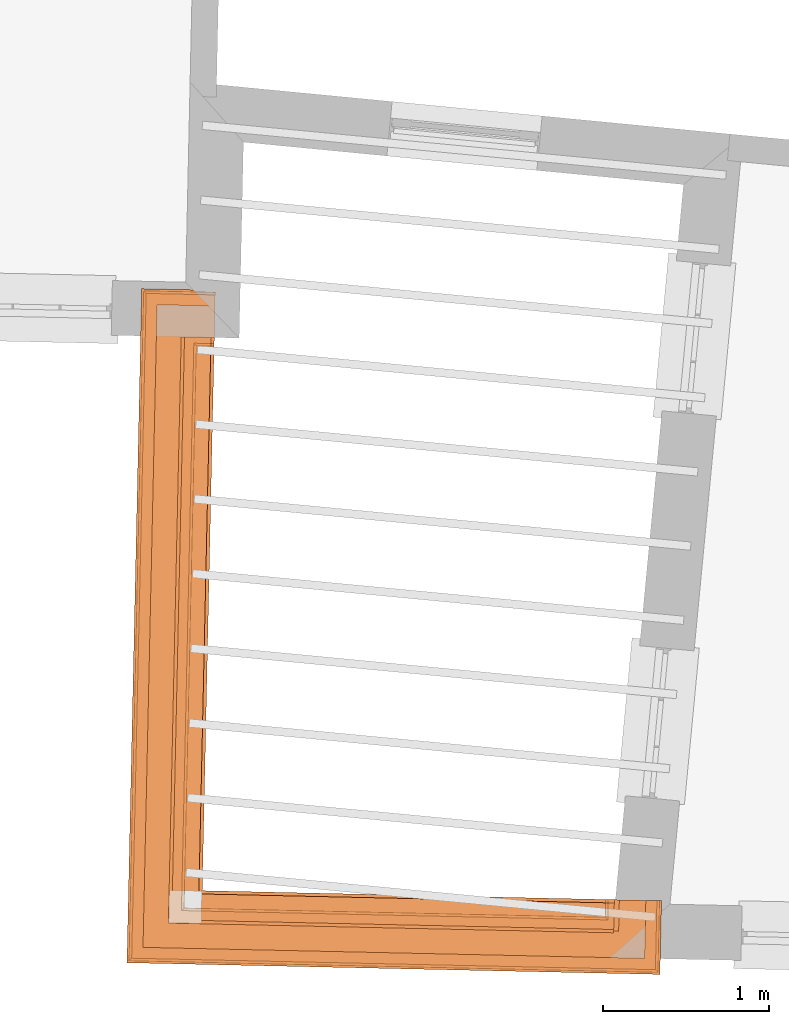
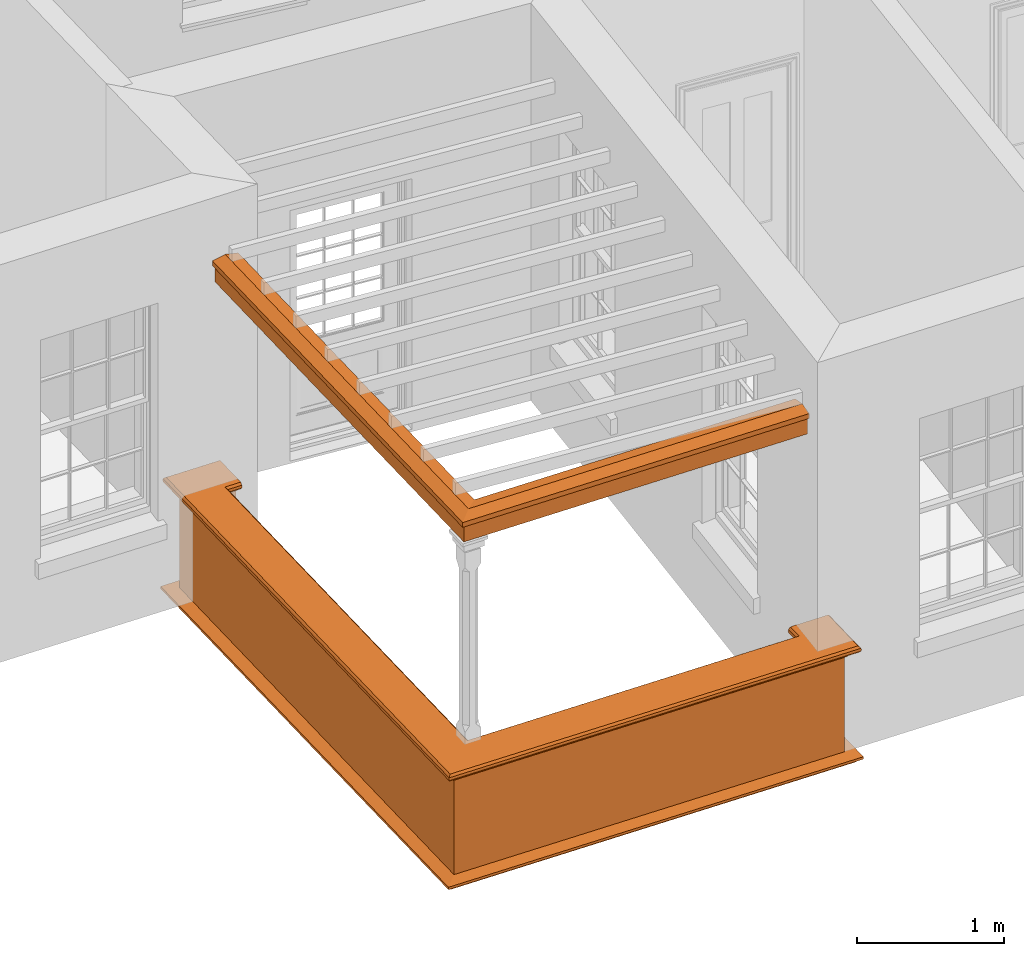
# One storey, part 11 of 12: 5 proxies.
"""IFC2X3 building model written with IfcOpenShell, lengths in metres."""

import ifcopenshell
import ifcopenshell.guid

model = None  # the IFC model being written
_history = None  # IfcOwnerHistory: only IFC2X3 demands one
_inside = {}  # id of a spatial element -> (the spatial element, [elements in it])
_under = {}  # id of a project, library or spatial element -> (it, [spatial elements below it])
_declared = {}  # id of a project -> (the project, [libraries it declares])
_typed = {}  # id of a type object -> (the type object, [elements of that type])
_made_of = {}  # id of a material, layer set ... -> (it, [elements and type objects made of it])


def new_model(schema):
    """Start an empty IFC model of exactly this schema.

    Asked for "IFC4X3", IfcOpenShell would pick the latest addendum, in which some entities
    have other attributes; the version numbers below select the first issue.
    IFC2X3 requires an IfcOwnerHistory on every rooted entity: one is made here for all.
    """
    global model, _history
    if schema == "IFC4X3":
        model = ifcopenshell.file(schema_version=(4, 3, 0, 0))
    else:
        model = ifcopenshell.file(schema=schema)
    _inside.clear()
    _under.clear()
    _declared.clear()
    _typed.clear()
    _made_of.clear()
    _history = None
    if model.schema == "IFC2X3":
        org = make("IfcOrganization", Name="unknown")
        user = make(
            "IfcPersonAndOrganization",
            ThePerson=make("IfcPerson", FamilyName="unknown"),
            TheOrganization=org,
        )
        app = make(
            "IfcApplication",
            ApplicationDeveloper=org,
            Version="unknown",
            ApplicationFullName="unknown",
            ApplicationIdentifier="unknown",
        )
        _history = make(
            "IfcOwnerHistory",
            OwningUser=user,
            OwningApplication=app,
            ChangeAction="ADDED",
            CreationDate=0,
        )
    return model


def make(cls, **values):
    """One entity of the class cls with the attributes given. An attribute that is None is left unset."""
    return model.create_entity(
        cls, **{name: value for name, value in values.items() if value is not None}
    )


def entity(cls, *values):
    """Any entity or typed value of the class cls, its attributes in the order of the schema. None: left unset."""
    e = model.create_entity(cls)
    for i, value in enumerate(values):
        if value is not None:
            e[i] = value
    return e


def rooted(cls, **values):
    """An entity with a GlobalId (a new one), such as an element, a storey or a relation."""
    return make(cls, GlobalId=ifcopenshell.guid.new(), OwnerHistory=_history, **values)


def si_unit(unit_type, name, prefix=None):
    """IfcSIUnit, for example si_unit("LENGTHUNIT", "METRE", prefix="MILLI")."""
    return make("IfcSIUnit", UnitType=unit_type, Prefix=prefix, Name=name)


def assignment(units):
    """IfcUnitAssignment: the units of a project."""
    return None if units is None else make("IfcUnitAssignment", Units=units)


def point(xyz):
    """IfcCartesianPoint."""
    return None if xyz is None else make("IfcCartesianPoint", Coordinates=xyz)


def direction(xyz):
    """IfcDirection."""
    return None if xyz is None else make("IfcDirection", DirectionRatios=xyz)


def frame(location, z_axis=None, x_axis=None):
    """IfcAxis2Placement3D, a coordinate frame: its origin and axes. An axis left out is left unset."""
    return make(
        "IfcAxis2Placement3D",
        Location=point(location),
        Axis=direction(z_axis),
        RefDirection=direction(x_axis),
    )


def origin():
    """The frame at (0, 0, 0) with its axes left unset."""
    return frame((0.0, 0.0, 0.0))


def place(relative_to, where):
    """IfcLocalPlacement: puts the frame where relative to a parent placement (None: the world)."""
    return make(
        "IfcLocalPlacement", PlacementRelTo=relative_to, RelativePlacement=where
    )


def context(
    kind, dimensions, precision=None, world=None, true_north=None, identifier=None
):
    """IfcGeometricRepresentationContext, for example the 3D "Model" context."""
    return make(
        "IfcGeometricRepresentationContext",
        ContextIdentifier=identifier,
        ContextType=kind,
        CoordinateSpaceDimension=dimensions,
        Precision=precision,
        WorldCoordinateSystem=world,
        TrueNorth=true_north,
    )


def subcontext(parent, identifier, kind, view, scale=None):
    """IfcGeometricRepresentationSubContext, for example "Body" below "Model"."""
    return make(
        "IfcGeometricRepresentationSubContext",
        ContextIdentifier=identifier,
        ContextType=kind,
        ParentContext=parent,
        TargetScale=scale,
        TargetView=view,
    )


def project(units=None, contexts=None):
    """IfcProject with its units and contexts."""
    return rooted(
        "IfcProject",
        Name="project",
        RepresentationContexts=contexts,
        UnitsInContext=assignment(units),
    )


def spatial(cls, under=None, at=None, **own):
    """A site, building, storey or space (cls), placed at a placement, below another one or the project."""
    s = rooted(cls, ObjectPlacement=at, **own)
    if under is not None:
        _under.setdefault(under.id(), (under, []))[1].append(s)
    return s


def shape(context_of_items, identifier, shape_type, items):
    """IfcShapeRepresentation: the items that make up one representation, for example the "Body"."""
    return make(
        "IfcShapeRepresentation",
        ContextOfItems=context_of_items,
        RepresentationIdentifier=identifier,
        RepresentationType=shape_type,
        Items=items,
    )


def made_of(thing, what):
    """Note that an element or type object is made of a material, layer set ...; save() writes the relation."""
    if what is not None:
        _made_of.setdefault(what.id(), (what, []))[1].append(thing)
    return thing


def element(
    cls,
    number,
    at=None,
    inside=None,
    cuts=None,
    type_object=None,
    material=None,
    context=None,
    identifier="Body",
    shape_type=None,
    held_by="IfcProductDefinitionShape",
    body=None,
    shapes=None,
    **own,
):
    """One element of the class cls, such as IfcWall. Its Tag is "e" and its number.

    at: its placement. inside: the storey or other place that contains it. cuts: it is an
    opening in that element (IfcRelVoidsElement). A single representation is given by context,
    identifier, shape_type and body (its items); several are given by shapes. held_by: the class
    of the entity that holds the representations. save() writes the other relations.
    """
    e = rooted(cls, Tag="e%d" % number, ObjectPlacement=at, **own)
    if body is not None:
        shapes = [shape(context, identifier, shape_type, body)]
    if shapes is not None:
        e.Representation = make(held_by, Representations=shapes)
    if inside is not None:
        _inside.setdefault(inside.id(), (inside, []))[1].append(e)
    if cuts is not None:
        rooted(
            "IfcRelVoidsElement", RelatingBuildingElement=cuts, RelatedOpeningElement=e
        )
    if type_object is not None:
        _typed.setdefault(type_object.id(), (type_object, []))[1].append(e)
    return made_of(e, material)


def aggregate(whole, parts):
    """IfcRelAggregates: a whole, such as a stair, and the parts it consists of."""
    return rooted("IfcRelAggregates", RelatingObject=whole, RelatedObjects=parts)


def save(model, path):
    """Write the relations noted so far, then the file.

    IfcRelAggregates (storeys below a building ...), IfcRelContainedInSpatialStructure (elements
    in a storey), IfcRelDefinesByType, IfcRelAssociatesMaterial and IfcRelDeclares: one each for
    every whole, place, type object, material and project.
    """
    for whole, parts in _under.values():
        aggregate(whole, parts)
    for where, things in _inside.values():
        rooted(
            "IfcRelContainedInSpatialStructure",
            RelatedElements=things,
            RelatingStructure=where,
        )
    for kind, things in _typed.values():
        rooted("IfcRelDefinesByType", RelatedObjects=things, RelatingType=kind)
    for what, things in _made_of.values():
        rooted("IfcRelAssociatesMaterial", RelatedObjects=things, RelatingMaterial=what)
    for by, libraries in _declared.values():
        rooted("IfcRelDeclares", RelatingContext=by, RelatedDefinitions=libraries)
    model.write(path)


model = new_model("IFC2X3")

# Units and contexts
model_context = context("Model", 3, world=origin())
body_context = subcontext(model_context, "Body", "Model", "MODEL_VIEW")
ifc_project = project(units=[si_unit("PLANEANGLEUNIT", "RADIAN"), si_unit("MASSUNIT", "GRAM", prefix="KILO"), si_unit("FORCEUNIT", "NEWTON", prefix="KILO"), si_unit("LENGTHUNIT", "METRE")], contexts=[model_context])

# Site, building, storey
site_placement = place(None, origin())
site = spatial("IfcSite", under=ifc_project, at=site_placement, CompositionType="ELEMENT")
building_placement = place(None, origin())
building = spatial("IfcBuilding", under=site, at=building_placement, Name="Building plot-18", CompositionType="ELEMENT")
storey_placement = place(None, frame((0.0, 0.0, 6.6)))
storey = spatial("IfcBuildingStorey", under=building, at=storey_placement, Name="Floor 1", CompositionType="ELEMENT", Elevation=6.6)

# Proxies
proxy_1_placement = place(storey_placement, origin())
axis2_placement3_d_1 = entity("IfcAxis2Placement3D", entity("IfcCartesianPoint", [0.0, 0.0, 0.0]))
element("IfcBuildingElementProxy", 1, at=proxy_1_placement, inside=storey, Name="parapet", CompositionType="ELEMENT", context=body_context, shape_type="SweptSolid", held_by="IfcProductRepresentation", body=[
    entity("IfcSurfaceCurveSweptAreaSolid", entity("IfcArbitraryClosedProfileDef", "AREA", None, entity("IfcPolyline", [entity("IfcCartesianPoint", [0.0, 0.25]), entity("IfcCartesianPoint", [0.795, 0.25]), entity("IfcCartesianPoint", [0.795, 0.09]), entity("IfcCartesianPoint", [0.02, 0.09]), entity("IfcCartesianPoint", [0.02, -0.08]), entity("IfcCartesianPoint", [0.0, -0.08]), entity("IfcCartesianPoint", [0.0, 0.25])])), axis2_placement3_d_1, entity("IfcPolyline", [entity("IfcCartesianPoint", [94.0271799475913, 20.2531681864854]), entity("IfcCartesianPoint", [93.9272038588954, 20.2553548938428]), entity("IfcCartesianPoint", [93.8532821448265, 16.875659930283]), entity("IfcCartesianPoint", [96.3815064977271, 16.820361839854]), entity("IfcCartesianPoint", [96.3836932050844, 16.9203379285499])]), 0.0, 1.0, entity("IfcPlane", axis2_placement3_d_1)),
])
proxy_2_placement = place(storey_placement, origin())
axis2_placement3_d_2 = entity("IfcAxis2Placement3D", entity("IfcCartesianPoint", [0.0, 0.0, 0.0]))
element("IfcBuildingElementProxy", 2, at=proxy_2_placement, inside=storey, Name="parapet", CompositionType="ELEMENT", context=body_context, shape_type="SweptSolid", held_by="IfcProductRepresentation", body=[
    entity("IfcSurfaceCurveSweptAreaSolid", entity("IfcArbitraryClosedProfileDef", "AREA", None, entity("IfcPolyline", [entity("IfcCartesianPoint", [0.795, 0.265]), entity("IfcCartesianPoint", [0.807, 0.268]), entity("IfcCartesianPoint", [0.816, 0.274]), entity("IfcCartesianPoint", [0.822, 0.283]), entity("IfcCartesianPoint", [0.825, 0.295]), entity("IfcCartesianPoint", [0.84, 0.295]), entity("IfcCartesianPoint", [0.84, 0.305]), entity("IfcCartesianPoint", [0.842, 0.317]), entity("IfcCartesianPoint", [0.849, 0.326]), entity("IfcCartesianPoint", [0.858, 0.333]), entity("IfcCartesianPoint", [0.87, 0.335]), entity("IfcCartesianPoint", [0.882, 0.333]), entity("IfcCartesianPoint", [0.891, 0.326]), entity("IfcCartesianPoint", [0.898, 0.317]), entity("IfcCartesianPoint", [0.9, 0.305]), entity("IfcCartesianPoint", [0.9, 0.035]), entity("IfcCartesianPoint", [0.898, 0.023]), entity("IfcCartesianPoint", [0.891, 0.014]), entity("IfcCartesianPoint", [0.882, 0.007]), entity("IfcCartesianPoint", [0.87, 0.005]), entity("IfcCartesianPoint", [0.858, 0.007]), entity("IfcCartesianPoint", [0.849, 0.014]), entity("IfcCartesianPoint", [0.842, 0.023]), entity("IfcCartesianPoint", [0.84, 0.035]), entity("IfcCartesianPoint", [0.84, 0.045]), entity("IfcCartesianPoint", [0.825, 0.045]), entity("IfcCartesianPoint", [0.822, 0.057]), entity("IfcCartesianPoint", [0.816, 0.066]), entity("IfcCartesianPoint", [0.807, 0.072]), entity("IfcCartesianPoint", [0.795, 0.075]), entity("IfcCartesianPoint", [0.795, 0.265])])), axis2_placement3_d_2, entity("IfcPolyline", [entity("IfcCartesianPoint", [94.0271799475913, 20.2531681864854]), entity("IfcCartesianPoint", [93.9272038588954, 20.2553548938428]), entity("IfcCartesianPoint", [93.8532821448265, 16.875659930283]), entity("IfcCartesianPoint", [96.3815064977271, 16.820361839854]), entity("IfcCartesianPoint", [96.3836932050844, 16.9203379285499])]), 0.0, 1.0, entity("IfcPlane", axis2_placement3_d_2)),
])
proxy_3_placement = place(storey_placement, origin())
axis2_placement3_d_3 = entity("IfcAxis2Placement3D", entity("IfcCartesianPoint", [0.0, 0.0, 0.0]))
element("IfcBuildingElementProxy", 3, at=proxy_3_placement, inside=storey, Name="parapet", CompositionType="ELEMENT", context=body_context, shape_type="SweptSolid", held_by="IfcProductRepresentation", body=[
    entity("IfcSurfaceCurveSweptAreaSolid", entity("IfcArbitraryClosedProfileDef", "AREA", None, entity("IfcPolyline", [entity("IfcCartesianPoint", [-0.1, 0.25]), entity("IfcCartesianPoint", [-0.1, 0.265]), entity("IfcCartesianPoint", [-0.085, 0.265]), entity("IfcCartesianPoint", [-0.084, 0.278]), entity("IfcCartesianPoint", [-0.081, 0.289]), entity("IfcCartesianPoint", [-0.074, 0.301]), entity("IfcCartesianPoint", [-0.065, 0.309]), entity("IfcCartesianPoint", [-0.055, 0.315]), entity("IfcCartesianPoint", [-0.044, 0.324]), entity("IfcCartesianPoint", [-0.038, 0.334]), entity("IfcCartesianPoint", [-0.035, 0.345]), entity("IfcCartesianPoint", [-0.015, 0.345]), entity("IfcCartesianPoint", [0.0, 0.25]), entity("IfcCartesianPoint", [-0.1, 0.25])])), axis2_placement3_d_3, entity("IfcPolyline", [entity("IfcCartesianPoint", [94.0271799475913, 20.2531681864854]), entity("IfcCartesianPoint", [93.9272038588954, 20.2553548938428]), entity("IfcCartesianPoint", [93.8532821448265, 16.875659930283]), entity("IfcCartesianPoint", [96.3815064977271, 16.820361839854]), entity("IfcCartesianPoint", [96.3836932050844, 16.9203379285499])]), 0.0, 1.0, entity("IfcPlane", axis2_placement3_d_3)),
])
proxy_4_placement = place(storey_placement, frame((0.0, 0.0, 3.3)))
axis2_placement3_d_4 = entity("IfcAxis2Placement3D", entity("IfcCartesianPoint", [0.0, 0.0, 0.0]))
element("IfcBuildingElementProxy", 4, at=proxy_4_placement, inside=storey, Name="pergola beam", CompositionType="ELEMENT", context=body_context, shape_type="SweptSolid", held_by="IfcProductRepresentation", body=[
    entity("IfcSurfaceCurveSweptAreaSolid", entity("IfcArbitraryClosedProfileDef", "AREA", None, entity("IfcPolyline", [entity("IfcCartesianPoint", [-0.7, -0.08]), entity("IfcCartesianPoint", [-0.7, 0.08]), entity("IfcCartesianPoint", [-0.56, 0.08]), entity("IfcCartesianPoint", [-0.56, -0.08]), entity("IfcCartesianPoint", [-0.7, -0.08])])), axis2_placement3_d_4, entity("IfcPolyline", [entity("IfcCartesianPoint", [93.9285158833098, 20.3153405470603]), entity("IfcCartesianPoint", [93.8532821448265, 16.875659930283]), entity("IfcCartesianPoint", [96.4414921509446, 16.8190498154396])]), 0.0, 1.0, entity("IfcPlane", axis2_placement3_d_4)),
])
proxy_5_placement = place(storey_placement, frame((0.0, 0.0, 3.3)))
axis2_placement3_d_5 = entity("IfcAxis2Placement3D", entity("IfcCartesianPoint", [0.0, 0.0, 0.0]))
element("IfcBuildingElementProxy", 5, at=proxy_5_placement, inside=storey, Name="pergola beam", CompositionType="ELEMENT", context=body_context, shape_type="SweptSolid", held_by="IfcProductRepresentation", body=[
    entity("IfcSurfaceCurveSweptAreaSolid", entity("IfcArbitraryClosedProfileDef", "AREA", None, entity("IfcPolyline", [entity("IfcCartesianPoint", [-0.5, 0.0]), entity("IfcCartesianPoint", [-0.52, -0.1]), entity("IfcCartesianPoint", [-0.56, -0.1]), entity("IfcCartesianPoint", [-0.56, 0.1]), entity("IfcCartesianPoint", [-0.52, 0.1]), entity("IfcCartesianPoint", [-0.5, 0.0])])), axis2_placement3_d_5, entity("IfcPolyline", [entity("IfcCartesianPoint", [93.9285158833098, 20.3153405470603]), entity("IfcCartesianPoint", [93.8532821448265, 16.875659930283]), entity("IfcCartesianPoint", [96.4414921509446, 16.8190498154396])]), 0.0, 1.0, entity("IfcPlane", axis2_placement3_d_5)),
])

save(model, "model.ifc")
